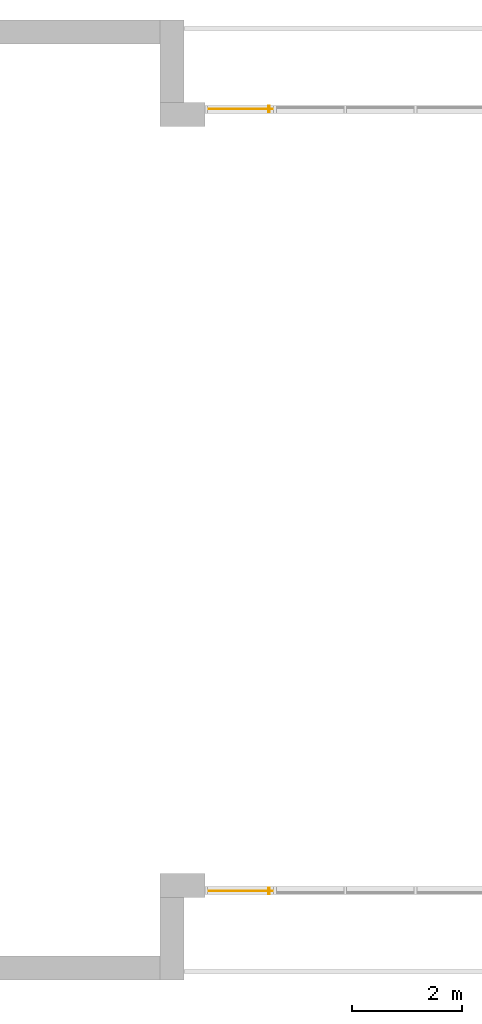
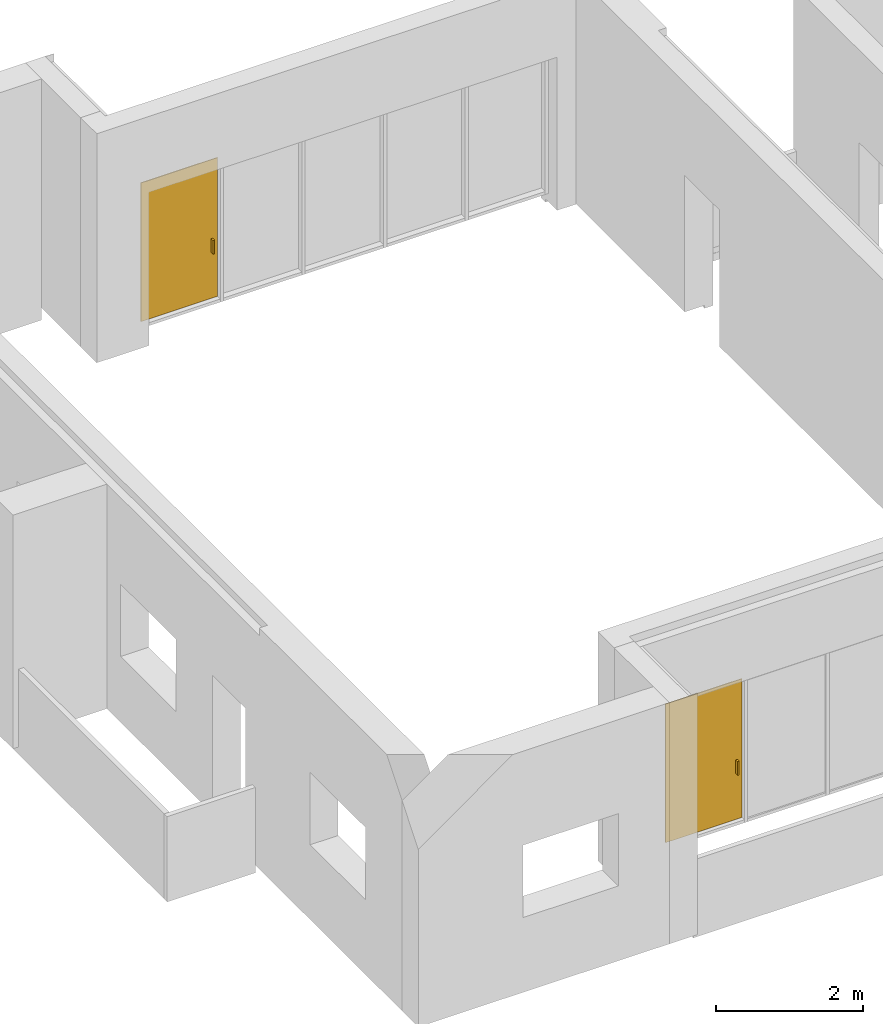
# One storey, part 4 of 4: 2 doors, 2 elements without a shape of their own.
"""IFC2X3 building model written with IfcOpenShell, lengths in millimetres."""

from ifc_helpers import new_model, entity, si_unit, converted_unit, derived_unit, direction, frame, frame_2d, origin, origin_2d_with_axis, place, context, subcontext, project, spatial, rectangle, extrude, source, transform, mapped, material, material_list, type_object, type_shapes, element, aggregate, save


model = new_model("IFC2X3")

# Units and contexts
model_context = context("Model", 3, precision=0.01, world=origin(), true_north=direction((6.12303176911189e-17, 1.0)))
body_context = subcontext(model_context, "Body", "Model", "MODEL_VIEW")
ifc_project = project(units=[si_unit("LENGTHUNIT", "METRE", prefix="MILLI"), si_unit("AREAUNIT", "SQUARE_METRE"), si_unit("VOLUMEUNIT", "CUBIC_METRE"), converted_unit("PLANEANGLEUNIT", "DEGREE", entity("IfcRatioMeasure", 0.0174532925199433), si_unit("PLANEANGLEUNIT", "RADIAN"), dimensions=[0, 0, 0, 0, 0, 0, 0]), si_unit("MASSUNIT", "GRAM", prefix="KILO"), derived_unit("MASSDENSITYUNIT", [(si_unit("MASSUNIT", "GRAM", prefix="KILO"), 1), (si_unit("LENGTHUNIT", "METRE"), -3)]), si_unit("TIMEUNIT", "SECOND"), si_unit("FREQUENCYUNIT", "HERTZ"), si_unit("THERMODYNAMICTEMPERATUREUNIT", "DEGREE_CELSIUS"), derived_unit("THERMALTRANSMITTANCEUNIT", [(si_unit("MASSUNIT", "GRAM", prefix="KILO"), 1), (si_unit("THERMODYNAMICTEMPERATUREUNIT", "KELVIN"), -1), (si_unit("TIMEUNIT", "SECOND"), -3)]), derived_unit("VOLUMETRICFLOWRATEUNIT", [(si_unit("LENGTHUNIT", "METRE"), 3), (si_unit("TIMEUNIT", "SECOND"), -1)]), si_unit("ELECTRICCURRENTUNIT", "AMPERE"), si_unit("ELECTRICVOLTAGEUNIT", "VOLT"), si_unit("POWERUNIT", "WATT"), si_unit("FORCEUNIT", "NEWTON", prefix="KILO"), si_unit("ILLUMINANCEUNIT", "LUX"), si_unit("LUMINOUSFLUXUNIT", "LUMEN"), si_unit("LUMINOUSINTENSITYUNIT", "CANDELA"), derived_unit("USERDEFINED", [(si_unit("MASSUNIT", "GRAM", prefix="KILO"), -1), (si_unit("LENGTHUNIT", "METRE"), -2), (si_unit("TIMEUNIT", "SECOND"), 3), (si_unit("LUMINOUSFLUXUNIT", "LUMEN"), 1)]), derived_unit("LINEARVELOCITYUNIT", [(si_unit("LENGTHUNIT", "METRE"), 1), (si_unit("TIMEUNIT", "SECOND"), -1)]), si_unit("PRESSUREUNIT", "PASCAL"), derived_unit("USERDEFINED", [(si_unit("LENGTHUNIT", "METRE"), -2), (si_unit("MASSUNIT", "GRAM", prefix="KILO"), 1), (si_unit("TIMEUNIT", "SECOND"), -2)])], contexts=[model_context])

# Site, building, storey
site_placement = place(None, origin())
site = spatial("IfcSite", under=ifc_project, at=site_placement, CompositionType="ELEMENT")
building_placement = place(site_placement, origin())
building = spatial("IfcBuilding", under=site, at=building_placement, CompositionType="ELEMENT")
storey_placement = place(building_placement, frame((0.0, 0.0, 12000.0)))
storey = spatial("IfcBuildingStorey", under=building, at=storey_placement, Name="03 Level", CompositionType="ELEMENT", Elevation=12000.0)

# Curtain wall, door
curtain_wall_type = type_object("IfcCurtainWallType", Name="Curtain Wall", PredefinedType="NOTDEFINED")
curtain_wall_1_placement = place(storey_placement, frame((0.0, 0.0, -12000.0)))
curtain_wall_1 = element("IfcCurtainWall", 1, at=curtain_wall_1_placement, inside=storey, type_object=curtain_wall_type, Name="Curtain Wall", ObjectType="Curtain Wall")
ifc_material_1 = material(Name="Glass")
ifc_material_2 = material(Name="Aluminum")
ifc_material_list_1 = material_list([ifc_material_1, ifc_material_2])
ifc_material_list_2 = material_list([ifc_material_1, ifc_material_2])
door_style_1 = type_object("IfcDoorStyle", Name="M_Door-Curtain-Wall-Single-Glass", ConstructionType="NOTDEFINED", OperationType="NOTDEFINED", ParameterTakesPrecedence=False, Sizeable=False, material=ifc_material_list_2)
shared_shape_1 = source(origin(), body_context, "Body", "SweptSolid", [
    extrude(rectangle(XDim=12.7000000000006, YDim=1204.99999999999, at=origin_2d_with_axis()), frame((0.0, 6.34999999998235, 0.0), z_axis=(0.0, 0.0, 1.0), x_axis=(0.0, 1.0, 0.0)), (0.0, 0.0, 1.0), 2300.0),
    extrude(rectangle(XDim=25.4, YDim=50.8, at=frame_2d((3.37507799486048e-14, 1.77635683940025e-15), x_axis=(1.0, 0.0))), frame((-513.599999999997, 38.0999999999827, 762.0), z_axis=(0.0, 0.0, 1.0), x_axis=(-1.0, 0.0, 0.0)), (0.0, 0.0, 1.0), 228.6),
    extrude(rectangle(XDim=25.3999999999997, YDim=50.8, at=frame_2d((-3.37507799486048e-14, 3.5527136788005e-15), x_axis=(1.0, 0.0))), frame((-513.599999999997, -25.400000000018, 762.0)), (0.0, 0.0, 1.0), 228.6),
])
type_shapes(door_style_1, [shared_shape_1])
door_1_placement = place(curtain_wall_1_placement, frame((22455.9900708518, -75951.2395851399, 12050.0), z_axis=(0.0, 0.0, 1.0), x_axis=(-1.0, 0.0, 0.0)))
door_1 = element("IfcDoor", 2, at=door_1_placement, type_object=door_style_1, material=ifc_material_list_1, OverallHeight=2300.0, OverallWidth=1205.0, context=body_context, shape_type="MappedRepresentation", body=[
    mapped(shared_shape_1, transform((0.0, 0.0, 0.0), scale=1.0)),
])
aggregate(curtain_wall_1, [door_1])

curtain_wall_2_placement = place(storey_placement, frame((0.0, 0.0, -12000.0)))
curtain_wall_2 = element("IfcCurtainWall", 3, at=curtain_wall_2_placement, inside=storey, type_object=curtain_wall_type, Name="Curtain Wall", ObjectType="Curtain Wall")
ifc_material_list_3 = material_list([ifc_material_1, ifc_material_2])
ifc_material_list_4 = material_list([ifc_material_1, ifc_material_2])
door_style_2 = type_object("IfcDoorStyle", Name="M_Door-Curtain-Wall-Single-Glass", ConstructionType="NOTDEFINED", OperationType="NOTDEFINED", ParameterTakesPrecedence=False, Sizeable=False, material=ifc_material_list_4)
shared_shape_2 = source(origin(), body_context, "Body", "SweptSolid", [
    extrude(rectangle(XDim=1204.99999999999, YDim=12.7000000000006, at=origin_2d_with_axis()), frame((0.0, -6.34999999998235, 0.0), z_axis=(0.0, 0.0, 1.0), x_axis=(-1.0, 0.0, 0.0)), (0.0, 0.0, 1.0), 2300.0),
    extrude(rectangle(XDim=50.8, YDim=25.4, at=frame_2d((-3.5527136788005e-15, -3.37507799486048e-14), x_axis=(1.0, 0.0))), frame((-513.599999999997, -38.0999999999827, 762.0), z_axis=(0.0, 0.0, 1.0), x_axis=(0.0, 1.0, 0.0)), (0.0, 0.0, 1.0), 228.6),
    extrude(rectangle(XDim=50.8, YDim=25.3999999999997, at=frame_2d((0.0, 3.37507799486048e-14), x_axis=(1.0, 0.0))), frame((-513.599999999997, 25.400000000018, 762.0), z_axis=(0.0, 0.0, 1.0), x_axis=(0.0, -1.0, 0.0)), (0.0, 0.0, 1.0), 228.6),
])
type_shapes(door_style_2, [shared_shape_2])
door_2_placement = place(curtain_wall_2_placement, frame((22455.9900708518, -61711.23958514, 12050.0), z_axis=(0.0, 0.0, 1.0), x_axis=(-1.0, 0.0, 0.0)))
door_2 = element("IfcDoor", 4, at=door_2_placement, type_object=door_style_2, material=ifc_material_list_3, OverallHeight=2300.0, OverallWidth=1205.0, context=body_context, shape_type="MappedRepresentation", body=[
    mapped(shared_shape_2, transform((0.0, 0.0, 0.0), scale=1.0)),
])
aggregate(curtain_wall_2, [door_2])

save(model, "model.ifc")
